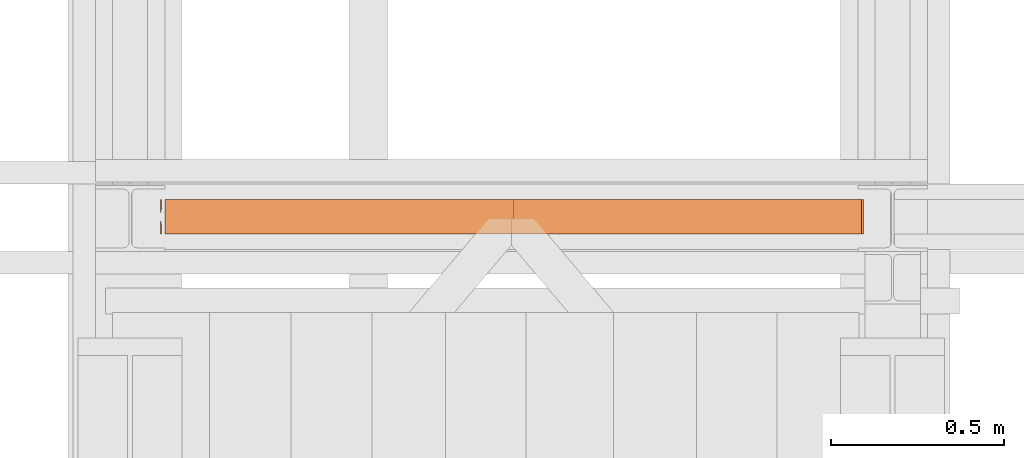
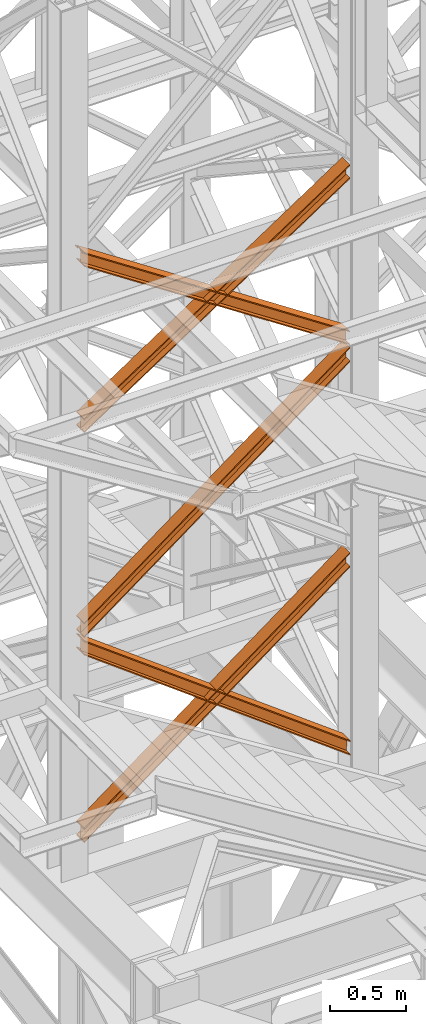
# One storey, part 88 of 208: 5 proxies.
"""IFC2X3 building model written with IfcOpenShell, lengths in millimetres."""

from ifc_helpers import new_model, entity, si_unit, converted_unit, frame, origin, origin_with_axes, place, context, subcontext, project, spatial, faceted_brep, element, save


model = new_model("IFC2X3")

# Units and contexts
model_context = context("Model", 3, precision=1e-05, world=origin())
plan_context = context("Plan", 3, precision=1e-05, world=origin())
body_context = subcontext(model_context, "Body", "Model", "MODEL_VIEW")
ifc_project = project(units=[si_unit("LENGTHUNIT", "METRE", prefix="MILLI"), converted_unit("PLANEANGLEUNIT", "DEGREE", entity("IfcPlaneAngleMeasure", 0.0174532925199433), si_unit("PLANEANGLEUNIT", "RADIAN"), dimensions=[0, 0, 0, 0, 0, 0, 0]), si_unit("AREAUNIT", "SQUARE_METRE"), si_unit("VOLUMEUNIT", "CUBIC_METRE")], contexts=[model_context, plan_context])

# Building, storey
building_placement = place(None, origin())
building = spatial("IfcBuilding", under=ifc_project, at=building_placement, CompositionType="COMPLEX")
storey_placement = place(building_placement, origin_with_axes())
storey = spatial("IfcBuildingStorey", under=building, at=storey_placement, Name="Geschoss", CompositionType="ELEMENT")

# Proxies
proxy_1_placement = place(storey_placement, frame((-3218.946337480857, -16013.12107325646, 8785.68637815495), z_axis=(0.0, 0.0, 1.0), x_axis=(1.0, 0.0, 0.0)))
element("IfcBuildingElementProxy", 1, at=proxy_1_placement, inside=storey, context=body_context, shape_type="Brep", body=[
    faceted_brep([(12.37358613197512, 100.0233329519015, 1330.225167941017), (2022.373573615001, 100.1729351296908, 0.02100513656660041), (2022.373573615001, 100.1718996660056, 9.435622162609434), (12.37358613197512, 100.0222968606722, 1339.639782821612), (12.37358613197512, 0.0233335574685043, 1330.214162804454), (2022.373573615001, 0.1729357352560328, 0.01000000000021828), (2022.373573615001, 100.1729351296908, 0.02100513656660041), (12.37358613197512, 100.0233329519015, 1330.225167941017), (12.37358613197557, 0.02229746624107065, 1339.628777685057), (2022.373573615001, 0.1719002715708484, 9.424617026043052), (2022.373573615001, 0.1729357352560328, 0.01000000000021828), (12.37358613197512, 0.0233335574685043, 1330.214162804454), (12.37358613197512, 47.52229717859518, 1339.634005124923), (2022.373573615001, 47.67189998392678, 9.429844465905262), (2022.373573615001, 0.1719002715708484, 9.424617026043052), (12.37358613197557, 0.02229746624107065, 1339.628777685057), (12.37358613197603, 47.5119362662881, 1433.780153930935), (2022.373573615001, 47.66154536059003, 103.5760147725105), (2022.373573615001, 47.67189998392678, 9.429844465905262), (12.37358613197512, 47.52229717859518, 1339.634005124923), (0.4039313696898716, 0.01106478197652905, 1441.696427017001), (2.373588218137684, 0.01120823570636276, 1440.39291091142), (2.373588218137684, 29.30668085241086, 1440.396134918205), (0.5090431708545111, 38.62249288135536, 1441.631113415808), (0.4039313696898716, 38.72760466098953, 1441.70068782511), (12.37358613197603, 47.5119362662881, 1433.780153930935), (12.37358613197512, 0.01193655393217341, 1433.774926491073), (2022.373573615001, 0.161545648234096, 103.5707873326446), (2022.373573615001, 47.66154536059003, 103.5760147725105), (0.009999999999763531, 0.01000000000021828, 1451.371745118717), (2.373588218138139, 0.01017214447529113, 1449.807525792019), (2.373588218137684, 0.01120823570636276, 1440.39291091142), (0.4039313696898716, 0.01106478197652905, 1441.696427017001), (12.37358613197512, 0.01193655393217341, 1433.774926491073), (12.37358613197557, 0.01090046270292078, 1443.189541371672), (2022.373573615001, 0.1605101872537489, 112.9854043679352), (2022.373573615001, 0.161545648234096, 103.5707873326446), (0.01000000000021828, 100.0099993944386, 1451.382750255283), (2.373588218137684, 100.0101715389137, 1449.818530928586), (2.373588218137684, 71.806685024736, 1449.815427096359), (0.5090431708545111, 62.49087299579151, 1451.048355158282), (0.009999999999763531, 61.99182992716487, 1451.378566303787), (12.37358613197557, 0.01090046270292078, 1443.189541371672), (12.37358613197512, 100.0108998571395, 1443.200546508238), (2022.373573615001, 100.1605095816922, 112.9964095044979), (2022.373573615001, 0.1605101872537489, 112.9854043679352), (2.373588218138139, 0.01017214447529113, 1449.807525792019), (0.009999999999763531, 0.01000000000021828, 1451.371745118717), (0.009999999999763531, 39.12153594998017, 1451.376049396686), (0.5090431708545111, 38.62249288135536, 1451.045728410436), (2.373588218137684, 29.30668085241086, 1449.810749912833), (0.4039313696903264, 100.0110641764131, 1441.707432153557), (2.373588218138139, 100.0112076301411, 1440.403916047975), (2.373588218137684, 100.0101715389137, 1449.818530928586), (0.01000000000021828, 100.0099993944386, 1451.382750255283), (12.37358613197512, 100.0108998571395, 1443.200546508238), (12.37358613197557, 100.0119359483706, 1433.785931627628), (2022.373573615001, 100.1615450426671, 103.5817924692037), (2022.373573615001, 100.1605095816922, 112.9964095044979), (12.37358613197512, 52.51193623601102, 1433.780704187766), (2022.373573615001, 52.66154533031295, 103.5765650293379), (2022.373573615001, 100.1615450426671, 103.5817924692037), (12.37358613197557, 100.0119359483706, 1433.785931627628), (2.373588218137684, 71.806685024736, 1440.400812101727), (2.373588218138139, 100.0112076301411, 1440.403916047975), (0.4039313696903264, 100.0110641764131, 1441.707432153557), (0.4039313696898716, 62.38576121615733, 1441.703291437565), (0.5090431708545111, 62.49087299579151, 1441.63374016365), (12.37358613197557, 52.52229714831447, 1339.63455538175), (2022.373573615001, 52.67189995364788, 9.43039472273631), (2022.373573615001, 52.66154533031295, 103.5765650293379), (12.37358613197512, 52.51193623601102, 1433.780704187766), (12.37358613197512, 100.0222968606722, 1339.639782821612), (2022.373573615001, 100.1718996660056, 9.435622162609434), (2022.373573615001, 52.67189995364788, 9.43039472273631), (12.37358613197557, 52.52229714831447, 1339.63455538175), (0.4039313696898716, 62.38576121615733, 1441.703291437565), (0.4039313696903264, 100.0110641764131, 1441.707432153557), (0.01000000000021828, 100.0099993944386, 1451.382750255283), (0.009999999999763531, 61.99182992716487, 1451.378566303787), (0.009999999999763531, 39.12153594998017, 1451.376049396686), (0.009999999999763531, 0.01000000000021828, 1451.371745118717), (0.4039313696898716, 0.01106478197652905, 1441.696427017001), (0.4039313696898716, 38.72760466098953, 1441.70068782511), (0.5090431708545111, 62.49087299579151, 1441.63374016365), (0.4039313696898716, 62.38576121615733, 1441.703291437565), (0.009999999999763531, 61.99182992716487, 1451.378566303787), (0.5090431708545111, 62.49087299579151, 1451.048355158282), (0.5090431708545111, 62.49087299579151, 1451.048355158282), (2.373588218137684, 71.806685024736, 1449.815427096359), (2.373588218137684, 71.806685024736, 1440.400812101727), (0.5090431708545111, 62.49087299579151, 1441.63374016365), (2.373588218137684, 71.806685024736, 1449.815427096359), (2.373588218137684, 100.0101715389137, 1449.818530928586), (2.373588218138139, 100.0112076301411, 1440.403916047975), (2.373588218137684, 71.806685024736, 1440.400812101727), (12.37358613197512, 100.0222968606722, 1339.639782821612), (12.37358613197557, 52.52229714831447, 1339.63455538175), (12.37358613197512, 52.51193623601102, 1433.780704187766), (12.37358613197557, 100.0119359483706, 1433.785931627628), (12.37358613197512, 100.0108998571395, 1443.200546508238), (12.37358613197557, 0.01090046270292078, 1443.189541371672), (12.37358613197512, 0.01193655393217341, 1433.774926491073), (12.37358613197603, 47.5119362662881, 1433.780153930935), (12.37358613197512, 47.52229717859518, 1339.634005124923), (12.37358613197557, 0.02229746624107065, 1339.628777685057), (12.37358613197512, 0.0233335574685043, 1330.214162804454), (12.37358613197512, 100.0233329519015, 1330.225167941017), (2.373588218137684, 29.30668085241086, 1440.396134918205), (2.373588218137684, 0.01120823570636276, 1440.39291091142), (2.373588218138139, 0.01017214447529113, 1449.807525792019), (2.373588218137684, 29.30668085241086, 1449.810749912833), (2.373588218137684, 29.30668085241086, 1449.810749912833), (0.5090431708545111, 38.62249288135536, 1451.045728410436), (0.5090431708545111, 38.62249288135536, 1441.631113415808), (2.373588218137684, 29.30668085241086, 1440.396134918205), (0.5090431708545111, 38.62249288135536, 1451.045728410436), (0.009999999999763531, 39.12153594998017, 1451.376049396686), (0.4039313696898716, 38.72760466098953, 1441.70068782511), (0.5090431708545111, 38.62249288135536, 1441.631113415808), (2022.373573615001, 100.1729351296908, 0.02100513656660041), (2022.373573615001, 0.1729357352560328, 0.01000000000021828), (2022.373573615001, 0.1719002715708484, 9.424617026043052), (2022.373573615001, 47.67189998392678, 9.429844465905262), (2022.373573615001, 47.66154536059003, 103.5760147725105), (2022.373573615001, 0.161545648234096, 103.5707873326446), (2022.373573615001, 0.1605101872537489, 112.9854043679352), (2022.373573615001, 100.1605095816922, 112.9964095044979), (2022.373573615001, 100.1615450426671, 103.5817924692037), (2022.373573615001, 52.66154533031295, 103.5765650293379), (2022.373573615001, 52.67189995364788, 9.43039472273631), (2022.373573615001, 100.1718996660056, 9.435622162609434)], [[[0, 1, 2, 3]], [[4, 5, 6, 7]], [[8, 9, 10, 11]], [[12, 13, 14, 15]], [[16, 17, 18, 19]], [[20, 21, 22, 23, 24]], [[25, 26, 27, 28]], [[29, 30, 31, 32]], [[33, 34, 35, 36]], [[37, 38, 39, 40, 41]], [[42, 43, 44, 45]], [[46, 47, 48, 49, 50]], [[51, 52, 53, 54]], [[55, 56, 57, 58]], [[59, 60, 61, 62]], [[63, 64, 65, 66, 67]], [[68, 69, 70, 71]], [[72, 73, 74, 75]], [[76, 77, 78, 79]], [[80, 81, 82, 83]], [[84, 85, 86, 87]], [[88, 89, 90, 91]], [[92, 93, 94, 95]], [[96, 97, 98, 99, 100, 101, 102, 103, 104, 105, 106, 107]], [[108, 109, 110, 111]], [[112, 113, 114, 115]], [[116, 117, 118, 119]], [[120, 121, 122, 123, 124, 125, 126, 127, 128, 129, 130, 131]]], orient=[[False], [False], [False], [False], [False], [False], [False], [False], [False], [False], [False], [False], [False], [False], [False], [False], [False], [False], [False], [False], [False], [False], [False], [False], [False], [False], [False], [False]]),
])
proxy_2_placement = place(storey_placement, frame((-3206.582751348882, -16013.11159793871, 8785.050753356181), z_axis=(0.0, 0.0, 1.0), x_axis=(1.0, 0.0, 0.0)))
element("IfcBuildingElementProxy", 2, at=proxy_2_placement, inside=storey, context=body_context, shape_type="Brep", body=[
    faceted_brep([(2010.009987483026, 100.0213960296205, 1340.168495796863), (0.01000000000067303, 100.1712583843328, 9.436734304987112), (0.01000000000067303, 100.1722939377632, 0.02100513655932446), (2010.009987483026, 100.0224320873658, 1330.752768748162), (2010.009987483026, 100.0224320873658, 1330.752768748162), (0.01000000000067303, 100.1722939377632, 0.02100513655932446), (0.01000000000021828, 0.1722945433284622, 0.01000000000021828), (2010.009987483026, 0.02243269293285266, 1330.741763611606), (2010.009987483026, 0.02243269293285266, 1330.741763611606), (0.01000000000021828, 0.1722945433284622, 0.01000000000021828), (0.01000000000067303, 0.1712589898997976, 9.425729168431644), (2010.009987483026, 0.02139663518937596, 1340.1574906603), (2010.009987483026, 0.02139663518937596, 1340.1574906603), (0.01000000000067303, 0.1712589898997976, 9.425729168431644), (0.01000000000021828, 47.67125870225755, 9.430956608297492), (2010.009987483026, 47.52139634754713, 1340.162718100166), (2010.009987483026, 47.52139634754713, 1340.162718100166), (0.01000000000021828, 47.67125870225755, 9.430956608297492), (0.01000000000067303, 47.66090317872477, 103.5882483377918), (2010.009987483026, 47.51103577010144, 1434.319988587145), (2010.009987483026, 47.51103577010144, 1434.319988587145), (0.01000000000067303, 47.66090317872477, 103.5882483377918), (0.01000000000067303, 0.1609034663688362, 103.583020897926), (2010.009987483026, 0.01103605774551397, 1434.31476114728), (2010.009987483026, 0.01103605774551397, 1434.31476114728), (0.01000000000067303, 0.1609034663688362, 103.583020897926), (0.01000000000067303, 0.1598679150920361, 112.998750075405), (2010.009987483026, 0.01000000000021828, 1443.730488195981), (2010.009987483026, 0.01000000000021828, 1443.730488195981), (0.01000000000067303, 0.1598679150920361, 112.998750075405), (0.01000000000021828, 100.159867309525, 113.0097552119678), (2010.009987483026, 100.009999394435, 1443.741493332544), (2010.009987483026, 100.009999394435, 1443.741493332544), (0.01000000000021828, 100.159867309525, 113.0097552119678), (0.01000000000067303, 100.1609028608018, 103.5940260344851), (2010.009987483026, 100.0110354521785, 1434.325766283846), (2010.009987483026, 100.0110354521785, 1434.325766283846), (0.01000000000067303, 100.1609028608018, 103.5940260344851), (0.01000000000067303, 52.66090314844587, 103.5887985946229), (2010.009987483026, 52.51103573982437, 1434.320538843973), (2010.009987483026, 52.51103573982437, 1434.320538843973), (0.01000000000067303, 52.66090314844587, 103.5887985946229), (0.01000000000112777, 52.67125867197683, 9.431506865121264), (2010.009987483026, 52.52139631726823, 1340.163268357001), (2010.009987483026, 52.52139631726823, 1340.163268357001), (0.01000000000112777, 52.67125867197683, 9.431506865121264), (0.01000000000067303, 100.1712583843328, 9.436734304987112), (2010.009987483026, 100.0213960296205, 1340.168495796863), (2010.009987483026, 100.0224320873658, 1330.752768748162), (2010.009987483026, 0.02243269293285266, 1330.741763611606), (2010.009987483026, 0.02139663518937596, 1340.1574906603), (2010.009987483026, 47.52139634754713, 1340.162718100166), (2010.009987483026, 47.51103577010144, 1434.319988587145), (2010.009987483026, 0.01103605774551397, 1434.31476114728), (2010.009987483026, 0.01000000000021828, 1443.730488195981), (2010.009987483026, 100.009999394435, 1443.741493332544), (2010.009987483026, 100.0110354521785, 1434.325766283846), (2010.009987483026, 52.51103573982437, 1434.320538843973), (2010.009987483026, 52.52139631726823, 1340.163268357001), (2010.009987483026, 100.0213960296205, 1340.168495796863), (0.01000000000067303, 100.1712583843328, 9.436734304987112), (0.01000000000112777, 52.67125867197683, 9.431506865121264), (0.01000000000067303, 52.66090314844587, 103.5887985946229), (0.01000000000067303, 100.1609028608018, 103.5940260344851), (0.01000000000021828, 100.159867309525, 113.0097552119678), (0.01000000000067303, 0.1598679150920361, 112.998750075405), (0.01000000000067303, 0.1609034663688362, 103.583020897926), (0.01000000000067303, 47.66090317872477, 103.5882483377918), (0.01000000000021828, 47.67125870225755, 9.430956608297492), (0.01000000000067303, 0.1712589898997976, 9.425729168431644), (0.01000000000021828, 0.1722945433284622, 0.01000000000021828), (0.01000000000067303, 100.1722939377632, 0.02100513655932446)], [[[0, 1, 2, 3]], [[4, 5, 6, 7]], [[8, 9, 10, 11]], [[12, 13, 14, 15]], [[16, 17, 18, 19]], [[20, 21, 22, 23]], [[24, 25, 26, 27]], [[28, 29, 30, 31]], [[32, 33, 34, 35]], [[36, 37, 38, 39]], [[40, 41, 42, 43]], [[44, 45, 46, 47]], [[48, 49, 50, 51, 52, 53, 54, 55, 56, 57, 58, 59]], [[60, 61, 62, 63, 64, 65, 66, 67, 68, 69, 70, 71]]], orient=[[False], [False], [False], [False], [False], [False], [False], [False], [False], [False], [False], [False], [False], [False]]),
])
proxy_3_placement = place(storey_placement, frame((-3206.582751348882, -16012.74656035545, 5499.689768811883), z_axis=(0.0, 0.0, 1.0), x_axis=(1.0, 0.0, 0.0)))
element("IfcBuildingElementProxy", 3, at=proxy_3_placement, inside=storey, context=body_context, shape_type="Brep", body=[
    faceted_brep([(0.01000000000067303, 100.0229428112289, 1505.703241650141), (2013.688487512514, 100.1858455764686, 0.02100513656296243), (2013.850456535914, 100.1847800613887, 9.702984703128095), (0.01000000000067303, 100.0218641931642, 1515.50632986583), (0.01000000000112777, 0.02294341679771605, 1505.692236513578), (2013.688487512514, 0.1858461820338562, 0.01000000000021828), (2013.688487512514, 100.1858455764686, 0.02100513656296243), (0.01000000000067303, 100.0229428112289, 1505.703241650141), (0.009999999999763531, 0.02186479873125791, 1515.495324729271), (2013.850456535915, 0.1847806669538841, 9.691979566568989), (2013.688487512514, 0.1858461820338562, 0.01000000000021828), (0.01000000000112777, 0.02294341679771605, 1505.692236513578), (0.01000000000067303, 47.52186451108355, 1515.500552169136), (2013.850456535915, 47.68478037930981, 9.697207006434837), (2013.850456535915, 0.1847806669538841, 9.691979566568989), (0.009999999999763531, 0.02186479873125791, 1515.495324729271), (0.01000000000067303, 47.51107833042624, 1613.531434326045), (2015.470146769921, 47.67412522851737, 106.517002672068), (2013.850456535915, 47.68478037930981, 9.697207006434837), (0.01000000000067303, 47.52186451108355, 1515.500552169136), (0.01000000000067303, 0.01107861806849542, 1613.526206886179), (2015.470146769921, 0.174125516157801, 106.5117752322021), (2015.470146769921, 47.67412522851737, 106.517002672068), (0.01000000000067303, 47.51107833042624, 1613.531434326045), (0.01000000000067303, 0.01000000000021828, 1623.329295101868), (2015.632115793322, 0.1730600010778289, 116.1937547987636), (2015.470146769921, 0.174125516157801, 106.5117752322021), (0.01000000000067303, 0.01107861806849542, 1613.526206886179), (0.01000000000021828, 100.0099993944386, 1623.340300238435), (2015.632115793321, 100.1730593955126, 116.2047599353264), (2015.632115793322, 0.1730600010778289, 116.1937547987636), (0.01000000000067303, 0.01000000000021828, 1623.329295101868), (0.01000000000112777, 100.0110780125051, 1613.537212022739), (2015.470146769921, 100.1741249105908, 106.5227803687612), (2015.632115793321, 100.1730593955126, 116.2047599353264), (0.01000000000021828, 100.0099993944386, 1623.340300238435), (0.01000000000021828, 52.51107830014917, 1613.531984582873), (2015.470146769921, 52.67412519823665, 106.5175529288954), (2015.470146769921, 100.1741249105908, 106.5227803687612), (0.01000000000112777, 100.0110780125051, 1613.537212022739), (0.01000000000067303, 52.52186448080829, 1515.501102425964), (2013.850456535914, 52.68478034903274, 9.697757263262247), (2015.470146769921, 52.67412519823665, 106.5175529288954), (0.01000000000021828, 52.51107830014917, 1613.531984582873), (0.01000000000067303, 100.0218641931642, 1515.50632986583), (2013.850456535914, 100.1847800613887, 9.702984703128095), (2013.850456535914, 52.68478034903274, 9.697757263262247), (0.01000000000067303, 52.52186448080829, 1515.501102425964), (2013.688487512514, 100.1858455764686, 0.02100513656296243), (2013.688487512514, 0.1858461820338562, 0.01000000000021828), (2013.850456535915, 0.1847806669538841, 9.691979566568989), (2013.850456535915, 47.68478037930981, 9.697207006434837), (2015.470146769921, 47.67412522851737, 106.517002672068), (2015.470146769921, 0.174125516157801, 106.5117752322021), (2015.632115793322, 0.1730600010778289, 116.1937547987636), (2015.632115793321, 100.1730593955126, 116.2047599353264), (2015.470146769921, 100.1741249105908, 106.5227803687612), (2015.470146769921, 52.67412519823665, 106.5175529288954), (2013.850456535914, 52.68478034903274, 9.697757263262247), (2013.850456535914, 100.1847800613887, 9.702984703128095), (0.01000000000067303, 100.0218641931642, 1515.50632986583), (0.01000000000067303, 52.52186448080829, 1515.501102425964), (0.01000000000021828, 52.51107830014917, 1613.531984582873), (0.01000000000112777, 100.0110780125051, 1613.537212022739), (0.01000000000021828, 100.0099993944386, 1623.340300238435), (0.01000000000067303, 0.01000000000021828, 1623.329295101868), (0.01000000000067303, 0.01107861806849542, 1613.526206886179), (0.01000000000067303, 47.51107833042624, 1613.531434326045), (0.01000000000067303, 47.52186451108355, 1515.500552169136), (0.009999999999763531, 0.02186479873125791, 1515.495324729271), (0.01000000000112777, 0.02294341679771605, 1505.692236513578), (0.01000000000067303, 100.0229428112289, 1505.703241650141)], [[[0, 1, 2, 3]], [[4, 5, 6, 7]], [[8, 9, 10, 11]], [[12, 13, 14, 15]], [[16, 17, 18, 19]], [[20, 21, 22, 23]], [[24, 25, 26, 27]], [[28, 29, 30, 31]], [[32, 33, 34, 35]], [[36, 37, 38, 39]], [[40, 41, 42, 43]], [[44, 45, 46, 47]], [[48, 49, 50, 51, 52, 53, 54, 55, 56, 57, 58, 59]], [[60, 61, 62, 63, 64, 65, 66, 67, 68, 69, 70, 71]]], orient=[[False], [False], [False], [False], [False], [False], [False], [False], [False], [False], [False], [False], [False], [False]]),
])
proxy_4_placement = place(storey_placement, frame((-3206.582751348882, -16012.74668220398, 5504.219540188055), z_axis=(0.0, 0.0, 1.0), x_axis=(1.0, 0.0, 0.0)))
element("IfcBuildingElementProxy", 4, at=proxy_4_placement, inside=storey, context=body_context, shape_type="Brep", body=[
    faceted_brep([(2010.009987483026, 100.0218596475406, 1511.076608371926), (0.01000000000067303, 100.1844513161013, 9.820176864343011), (0.01000000000021828, 100.1855295209298, 0.02100513655932446), (2010.009987483026, 100.0229378523673, 1501.277436644132), (2010.009987483026, 100.0229378523673, 1501.277436644132), (0.01000000000021828, 100.1855295209298, 0.02100513655932446), (0.01000000000021828, 0.1855301264913578, 0.01000000000021828), (2010.009987483026, 0.02293845793246874, 1501.266431507576), (2010.009987483026, 0.02293845793246874, 1501.266431507576), (0.01000000000021828, 0.1855301264913578, 0.01000000000021828), (0.01000000000112777, 0.1844519216665503, 9.809171727787543), (2010.009987483026, 0.02186025310402329, 1511.06560323536), (2010.009987483026, 0.02186025310402329, 1511.06560323536), (0.01000000000112777, 0.1844519216665503, 9.809171727787543), (0.01000000000067303, 47.6844516340243, 9.814399167646116), (2010.009987483026, 47.52185996546359, 1511.070830675226), (2010.009987483026, 47.52185996546359, 1511.070830675226), (0.01000000000067303, 47.6844516340243, 9.814399167646116), (0.01000000000067303, 47.6736695857453, 107.8061164454975), (2010.009987483026, 47.51107791718459, 1609.062547953077), (2010.009987483026, 47.51107791718459, 1609.062547953077), (0.01000000000067303, 47.6736695857453, 107.8061164454975), (0.01000000000112777, 0.1736698733893718, 107.8008890056317), (2010.009987483026, 0.01107820482866373, 1609.057320513211), (2010.009987483026, 0.01107820482866373, 1609.057320513211), (0.01000000000112777, 0.1736698733893718, 107.8008890056317), (0.01000000000067303, 0.1725916685609263, 117.6000607334227), (2010.009987483026, 0.01000000000021828, 1618.856492240995), (2010.009987483026, 0.01000000000021828, 1618.856492240995), (0.01000000000067303, 0.1725916685609263, 117.6000607334227), (0.01000000000067303, 100.1725910629975, 117.6110658699781), (2010.009987483026, 100.009999394435, 1618.867497377558), (2010.009987483026, 100.009999394435, 1618.867497377558), (0.01000000000067303, 100.1725910629975, 117.6110658699781), (0.01000000000021828, 100.1736692678242, 107.8118941421981), (2010.009987483026, 100.0110775992634, 1609.068325649774), (2010.009987483026, 100.0110775992634, 1609.068325649774), (0.01000000000021828, 100.1736692678242, 107.8118941421981), (0.01000000000021828, 52.67366955546459, 107.806666702325), (2010.009987483026, 52.51107788690388, 1609.063098209905), (2010.009987483026, 52.51107788690388, 1609.063098209905), (0.01000000000021828, 52.67366955546459, 107.806666702325), (0.01000000000067303, 52.6844516037454, 9.814949424477163), (2010.009987483026, 52.52185993518287, 1511.071380932057), (2010.009987483026, 52.52185993518287, 1511.071380932057), (0.01000000000067303, 52.6844516037454, 9.814949424477163), (0.01000000000067303, 100.1844513161013, 9.820176864343011), (2010.009987483026, 100.0218596475406, 1511.076608371926), (0.01000000000067303, 100.1844513161013, 9.820176864343011), (0.01000000000067303, 52.6844516037454, 9.814949424477163), (0.01000000000021828, 52.67366955546459, 107.806666702325), (0.01000000000021828, 100.1736692678242, 107.8118941421981), (0.01000000000067303, 100.1725910629975, 117.6110658699781), (0.01000000000067303, 0.1725916685609263, 117.6000607334227), (0.01000000000112777, 0.1736698733893718, 107.8008890056317), (0.01000000000067303, 47.6736695857453, 107.8061164454975), (0.01000000000067303, 47.6844516340243, 9.814399167646116), (0.01000000000112777, 0.1844519216665503, 9.809171727787543), (0.01000000000021828, 0.1855301264913578, 0.01000000000021828), (0.01000000000021828, 100.1855295209298, 0.02100513655932446), (2010.009987483026, 100.0229378523673, 1501.277436644132), (2010.009987483026, 0.02293845793246874, 1501.266431507576), (2010.009987483026, 0.02186025310402329, 1511.06560323536), (2010.009987483026, 47.52185996546359, 1511.070830675226), (2010.009987483026, 47.51107791718459, 1609.062547953077), (2010.009987483026, 0.01107820482866373, 1609.057320513211), (2010.009987483026, 0.01000000000021828, 1618.856492240995), (2010.009987483026, 100.009999394435, 1618.867497377558), (2010.009987483026, 100.0110775992634, 1609.068325649774), (2010.009987483026, 52.51107788690388, 1609.063098209905), (2010.009987483026, 52.52185993518287, 1511.071380932057), (2010.009987483026, 100.0218596475406, 1511.076608371926)], [[[0, 1, 2, 3]], [[4, 5, 6, 7]], [[8, 9, 10, 11]], [[12, 13, 14, 15]], [[16, 17, 18, 19]], [[20, 21, 22, 23]], [[24, 25, 26, 27]], [[28, 29, 30, 31]], [[32, 33, 34, 35]], [[36, 37, 38, 39]], [[40, 41, 42, 43]], [[44, 45, 46, 47]], [[48, 49, 50, 51, 52, 53, 54, 55, 56, 57, 58, 59]], [[60, 61, 62, 63, 64, 65, 66, 67, 68, 69, 70, 71]]], orient=[[False], [False], [False], [False], [False], [False], [False], [False], [False], [False], [False], [False], [False], [False]]),
])
proxy_5_placement = place(storey_placement, frame((-3206.582751348882, -16012.93388349018, 7147.441290649187), z_axis=(0.0, 0.0, 1.0), x_axis=(1.0, 0.0, 0.0)))
element("IfcBuildingElementProxy", 5, at=proxy_5_placement, inside=storey, context=body_context, shape_type="Brep", body=[
    faceted_brep([(2010.009987483026, 100.0218623025594, 1512.063556389601), (0.01000000000067303, 100.1844166626888, 9.822513400360549), (0.01000000000112777, 100.1854951088844, 0.02100513655932446), (2010.009987483026, 100.0229407487532, 1502.262048125804), (2010.009987483026, 100.0229407487532, 1502.262048125804), (0.01000000000112777, 100.1854951088844, 0.02100513655932446), (0.01000000000112777, 0.1854957144496439, 0.01000000000021828), (2010.009987483026, 0.02294135431657196, 1502.251042989237), (2010.009987483026, 0.02294135431657196, 1502.251042989237), (0.01000000000112777, 0.1854957144496439, 0.01000000000021828), (0.01000000000067303, 0.1844172682540375, 9.811508263797805), (2010.009987483026, 0.02186290812460356, 1512.052551253039), (2010.009987483026, 0.02186290812460356, 1512.052551253039), (0.01000000000067303, 0.1844172682540375, 9.811508263797805), (0.01000000000067303, 47.68441698061179, 9.816735703663653), (2010.009987483026, 47.52186262048053, 1512.057778692908), (2010.009987483026, 47.52186262048053, 1512.057778692908), (0.01000000000067303, 47.68441698061179, 9.816735703663653), (0.01000000000067303, 47.67363251868301, 107.8318183416577), (2010.009987483026, 47.51107815854994, 1610.072861330906), (2010.009987483026, 47.51107815854994, 1610.072861330906), (0.01000000000067303, 47.67363251868301, 107.8318183416577), (0.01000000000021828, 0.1736328063234396, 107.8265909017955), (2010.009987483026, 0.01107844619400566, 1610.067633891033), (2010.009987483026, 0.01107844619400566, 1610.067633891033), (0.01000000000021828, 0.1736328063234396, 107.8265909017955), (0.01000000000067303, 0.1725543601296522, 117.6280991655931), (2010.009987483026, 0.00999999999839929, 1619.86914215483), (2010.009987483026, 0.00999999999839929, 1619.86914215483), (0.01000000000067303, 0.1725543601296522, 117.6280991655931), (0.01000000000067303, 100.1725537545644, 117.6391043021558), (2010.009987483025, 100.0099993944332, 1619.880147291397), (2010.009987483025, 100.0099993944332, 1619.880147291397), (0.01000000000067303, 100.1725537545644, 117.6391043021558), (0.01000000000067303, 100.17363220076, 107.8375960383546), (2010.009987483026, 100.0110778406288, 1610.078639027603), (2010.009987483026, 100.0110778406288, 1610.078639027603), (0.01000000000067303, 100.17363220076, 107.8375960383546), (0.01000000000021828, 52.67363248840229, 107.8323685984888), (2010.009987483026, 52.51107812827286, 1610.073411587733), (2010.009987483026, 52.51107812827286, 1610.073411587733), (0.01000000000021828, 52.67363248840229, 107.8323685984888), (0.01000000000067303, 52.68441695033289, 9.817285960491063), (2010.009987483026, 52.52186259020164, 1512.058328949732), (2010.009987483026, 52.52186259020164, 1512.058328949732), (0.01000000000067303, 52.68441695033289, 9.817285960491063), (0.01000000000067303, 100.1844166626888, 9.822513400360549), (2010.009987483026, 100.0218623025594, 1512.063556389601), (0.01000000000067303, 100.1844166626888, 9.822513400360549), (0.01000000000067303, 52.68441695033289, 9.817285960491063), (0.01000000000021828, 52.67363248840229, 107.8323685984888), (0.01000000000067303, 100.17363220076, 107.8375960383546), (0.01000000000067303, 100.1725537545644, 117.6391043021558), (0.01000000000067303, 0.1725543601296522, 117.6280991655931), (0.01000000000021828, 0.1736328063234396, 107.8265909017955), (0.01000000000067303, 47.67363251868301, 107.8318183416577), (0.01000000000067303, 47.68441698061179, 9.816735703663653), (0.01000000000067303, 0.1844172682540375, 9.811508263797805), (0.01000000000112777, 0.1854957144496439, 0.01000000000021828), (0.01000000000112777, 100.1854951088844, 0.02100513655932446), (2010.009987483026, 100.0229407487532, 1502.262048125804), (2010.009987483026, 0.02294135431657196, 1502.251042989237), (2010.009987483026, 0.02186290812460356, 1512.052551253039), (2010.009987483026, 47.52186262048053, 1512.057778692908), (2010.009987483026, 47.51107815854994, 1610.072861330906), (2010.009987483026, 0.01107844619400566, 1610.067633891033), (2010.009987483026, 0.00999999999839929, 1619.86914215483), (2010.009987483025, 100.0099993944332, 1619.880147291397), (2010.009987483026, 100.0110778406288, 1610.078639027603), (2010.009987483026, 52.51107812827286, 1610.073411587733), (2010.009987483026, 52.52186259020164, 1512.058328949732), (2010.009987483026, 100.0218623025594, 1512.063556389601)], [[[0, 1, 2, 3]], [[4, 5, 6, 7]], [[8, 9, 10, 11]], [[12, 13, 14, 15]], [[16, 17, 18, 19]], [[20, 21, 22, 23]], [[24, 25, 26, 27]], [[28, 29, 30, 31]], [[32, 33, 34, 35]], [[36, 37, 38, 39]], [[40, 41, 42, 43]], [[44, 45, 46, 47]], [[48, 49, 50, 51, 52, 53, 54, 55, 56, 57, 58, 59]], [[60, 61, 62, 63, 64, 65, 66, 67, 68, 69, 70, 71]]], orient=[[False], [False], [False], [False], [False], [False], [False], [False], [False], [False], [False], [False], [False], [False]]),
])

save(model, "model.ifc")
